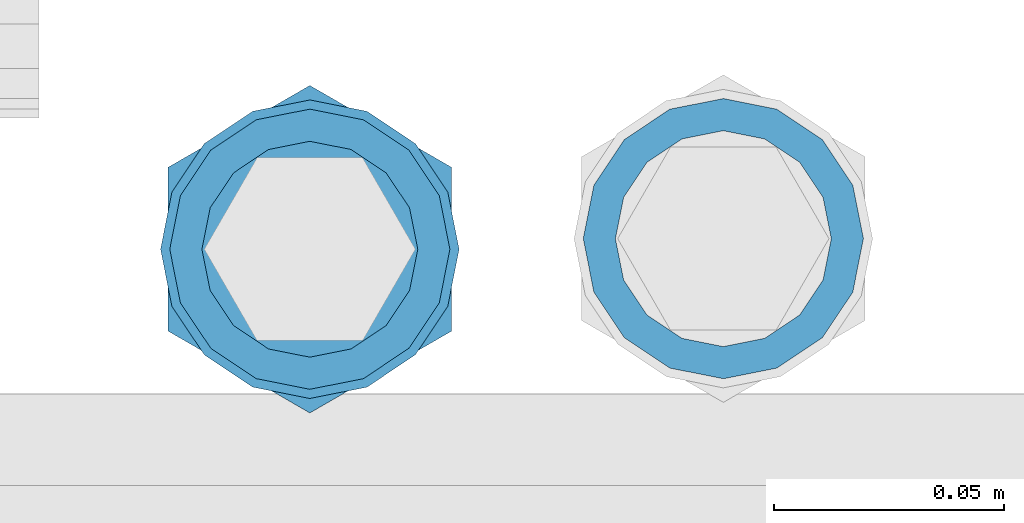
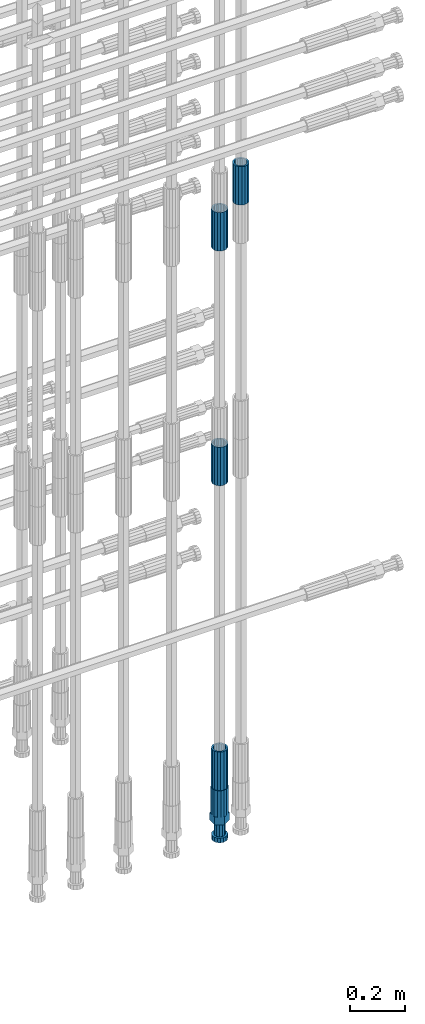
# One storey, part 103 of 119: 5 beams.
"""IFC2X3 building model written with IfcOpenShell, lengths in millimetres."""

import ifcopenshell
import ifcopenshell.guid

model = None  # the IFC model being written
_history = None  # IfcOwnerHistory: only IFC2X3 demands one
_inside = {}  # id of a spatial element -> (the spatial element, [elements in it])
_under = {}  # id of a project, library or spatial element -> (it, [spatial elements below it])
_declared = {}  # id of a project -> (the project, [libraries it declares])
_typed = {}  # id of a type object -> (the type object, [elements of that type])
_made_of = {}  # id of a material, layer set ... -> (it, [elements and type objects made of it])


def new_model(schema):
    """Start an empty IFC model of exactly this schema.

    Asked for "IFC4X3", IfcOpenShell would pick the latest addendum, in which some entities
    have other attributes; the version numbers below select the first issue.
    IFC2X3 requires an IfcOwnerHistory on every rooted entity: one is made here for all.
    """
    global model, _history
    if schema == "IFC4X3":
        model = ifcopenshell.file(schema_version=(4, 3, 0, 0))
    else:
        model = ifcopenshell.file(schema=schema)
    _inside.clear()
    _under.clear()
    _declared.clear()
    _typed.clear()
    _made_of.clear()
    _history = None
    if model.schema == "IFC2X3":
        org = make("IfcOrganization", Name="unknown")
        user = make(
            "IfcPersonAndOrganization",
            ThePerson=make("IfcPerson", FamilyName="unknown"),
            TheOrganization=org,
        )
        app = make(
            "IfcApplication",
            ApplicationDeveloper=org,
            Version="unknown",
            ApplicationFullName="unknown",
            ApplicationIdentifier="unknown",
        )
        _history = make(
            "IfcOwnerHistory",
            OwningUser=user,
            OwningApplication=app,
            ChangeAction="ADDED",
            CreationDate=0,
        )
    return model


def make(cls, **values):
    """One entity of the class cls with the attributes given. An attribute that is None is left unset."""
    return model.create_entity(
        cls, **{name: value for name, value in values.items() if value is not None}
    )


def rooted(cls, **values):
    """An entity with a GlobalId (a new one), such as an element, a storey or a relation."""
    return make(cls, GlobalId=ifcopenshell.guid.new(), OwnerHistory=_history, **values)


def si_unit(unit_type, name, prefix=None):
    """IfcSIUnit, for example si_unit("LENGTHUNIT", "METRE", prefix="MILLI")."""
    return make("IfcSIUnit", UnitType=unit_type, Prefix=prefix, Name=name)


def assignment(units):
    """IfcUnitAssignment: the units of a project."""
    return None if units is None else make("IfcUnitAssignment", Units=units)


def point(xyz):
    """IfcCartesianPoint."""
    return None if xyz is None else make("IfcCartesianPoint", Coordinates=xyz)


def direction(xyz):
    """IfcDirection."""
    return None if xyz is None else make("IfcDirection", DirectionRatios=xyz)


def frame(location, z_axis=None, x_axis=None):
    """IfcAxis2Placement3D, a coordinate frame: its origin and axes. An axis left out is left unset."""
    return make(
        "IfcAxis2Placement3D",
        Location=point(location),
        Axis=direction(z_axis),
        RefDirection=direction(x_axis),
    )


def origin_with_axes():
    """The frame at (0, 0, 0) with the z axis (0, 0, 1) and the x axis (1, 0, 0) written out."""
    return frame((0.0, 0.0, 0.0), z_axis=(0.0, 0.0, 1.0), x_axis=(1.0, 0.0, 0.0))


def place(relative_to, where):
    """IfcLocalPlacement: puts the frame where relative to a parent placement (None: the world)."""
    return make(
        "IfcLocalPlacement", PlacementRelTo=relative_to, RelativePlacement=where
    )


def context(
    kind, dimensions, precision=None, world=None, true_north=None, identifier=None
):
    """IfcGeometricRepresentationContext, for example the 3D "Model" context."""
    return make(
        "IfcGeometricRepresentationContext",
        ContextIdentifier=identifier,
        ContextType=kind,
        CoordinateSpaceDimension=dimensions,
        Precision=precision,
        WorldCoordinateSystem=world,
        TrueNorth=true_north,
    )


def subcontext(parent, identifier, kind, view, scale=None):
    """IfcGeometricRepresentationSubContext, for example "Body" below "Model"."""
    return make(
        "IfcGeometricRepresentationSubContext",
        ContextIdentifier=identifier,
        ContextType=kind,
        ParentContext=parent,
        TargetScale=scale,
        TargetView=view,
    )


def project(units=None, contexts=None):
    """IfcProject with its units and contexts."""
    return rooted(
        "IfcProject",
        Name="project",
        RepresentationContexts=contexts,
        UnitsInContext=assignment(units),
    )


def spatial(cls, under=None, at=None, **own):
    """A site, building, storey or space (cls), placed at a placement, below another one or the project."""
    s = rooted(cls, ObjectPlacement=at, **own)
    if under is not None:
        _under.setdefault(under.id(), (under, []))[1].append(s)
    return s


def faces_of(points, faces, orient=None, outer=None):
    """IfcFace entities. A face is a list of loops; a loop is a list of indices into points, from 0.

    orient and outer hold one flag for each loop. By default every Orientation is true, the
    first loop of a face is its IfcFaceOuterBound and the others are IfcFaceBound.
    """
    made = []
    for i, loops in enumerate(faces):
        bounds = []
        for j, loop in enumerate(loops):
            is_outer = j == 0 if outer is None else outer[i][j]
            bounds.append(
                make(
                    "IfcFaceOuterBound" if is_outer else "IfcFaceBound",
                    Bound=make("IfcPolyLoop", Polygon=[points[k] for k in loop]),
                    Orientation=True if orient is None else orient[i][j],
                )
            )
        made.append(make("IfcFace", Bounds=bounds))
    return made


def faceted_brep(points, faces, orient=None, outer=None, voids=None):
    """IfcFacetedBrep: a solid bounded by flat faces; with voids (closed shells), ...WithVoids."""
    shared = [point(p) for p in points]
    hull = make("IfcClosedShell", CfsFaces=faces_of(shared, faces, orient, outer))
    if voids is None:
        return make("IfcFacetedBrep", Outer=hull)
    return make(
        "IfcFacetedBrepWithVoids",
        Outer=hull,
        Voids=[
            make(cls, CfsFaces=faces_of(shared, fs, o, b)) for cls, fs, o, b in voids
        ],
    )


def shape(context_of_items, identifier, shape_type, items):
    """IfcShapeRepresentation: the items that make up one representation, for example the "Body"."""
    return make(
        "IfcShapeRepresentation",
        ContextOfItems=context_of_items,
        RepresentationIdentifier=identifier,
        RepresentationType=shape_type,
        Items=items,
    )


def material(Name=None, Category=None):
    """IfcMaterial."""
    return make("IfcMaterial", Name=Name, Category=Category)


def made_of(thing, what):
    """Note that an element or type object is made of a material, layer set ...; save() writes the relation."""
    if what is not None:
        _made_of.setdefault(what.id(), (what, []))[1].append(thing)
    return thing


def type_object(cls, material=None, **own):
    """A type object (cls), such as IfcWallType, which elements share."""
    return made_of(rooted(cls, **own), material)


def element(
    cls,
    number,
    at=None,
    inside=None,
    cuts=None,
    type_object=None,
    material=None,
    context=None,
    identifier="Body",
    shape_type=None,
    held_by="IfcProductDefinitionShape",
    body=None,
    shapes=None,
    **own,
):
    """One element of the class cls, such as IfcWall. Its Tag is "e" and its number.

    at: its placement. inside: the storey or other place that contains it. cuts: it is an
    opening in that element (IfcRelVoidsElement). A single representation is given by context,
    identifier, shape_type and body (its items); several are given by shapes. held_by: the class
    of the entity that holds the representations. save() writes the other relations.
    """
    e = rooted(cls, Tag="e%d" % number, ObjectPlacement=at, **own)
    if body is not None:
        shapes = [shape(context, identifier, shape_type, body)]
    if shapes is not None:
        e.Representation = make(held_by, Representations=shapes)
    if inside is not None:
        _inside.setdefault(inside.id(), (inside, []))[1].append(e)
    if cuts is not None:
        rooted(
            "IfcRelVoidsElement", RelatingBuildingElement=cuts, RelatedOpeningElement=e
        )
    if type_object is not None:
        _typed.setdefault(type_object.id(), (type_object, []))[1].append(e)
    return made_of(e, material)


def aggregate(whole, parts):
    """IfcRelAggregates: a whole, such as a stair, and the parts it consists of."""
    return rooted("IfcRelAggregates", RelatingObject=whole, RelatedObjects=parts)


def save(model, path):
    """Write the relations noted so far, then the file.

    IfcRelAggregates (storeys below a building ...), IfcRelContainedInSpatialStructure (elements
    in a storey), IfcRelDefinesByType, IfcRelAssociatesMaterial and IfcRelDeclares: one each for
    every whole, place, type object, material and project.
    """
    for whole, parts in _under.values():
        aggregate(whole, parts)
    for where, things in _inside.values():
        rooted(
            "IfcRelContainedInSpatialStructure",
            RelatedElements=things,
            RelatingStructure=where,
        )
    for kind, things in _typed.values():
        rooted("IfcRelDefinesByType", RelatedObjects=things, RelatingType=kind)
    for what, things in _made_of.values():
        rooted("IfcRelAssociatesMaterial", RelatedObjects=things, RelatingMaterial=what)
    for by, libraries in _declared.values():
        rooted("IfcRelDeclares", RelatingContext=by, RelatedDefinitions=libraries)
    model.write(path)


model = new_model("IFC2X3")

# Units and contexts
model_context = context("Model", 3, precision=1e-05, world=origin_with_axes())
body_context = subcontext(model_context, "Body", "Model", "MODEL_VIEW")
ifc_project = project(units=[si_unit("LENGTHUNIT", "METRE", prefix="MILLI"), si_unit("AREAUNIT", "SQUARE_METRE"), si_unit("VOLUMEUNIT", "CUBIC_METRE"), si_unit("MASSUNIT", "GRAM", prefix="KILO"), si_unit("TIMEUNIT", "SECOND"), si_unit("PLANEANGLEUNIT", "RADIAN"), si_unit("SOLIDANGLEUNIT", "STERADIAN"), si_unit("THERMODYNAMICTEMPERATUREUNIT", "DEGREE_CELSIUS"), si_unit("LUMINOUSINTENSITYUNIT", "LUMEN")], contexts=[model_context])

# Site, building, storey
site_placement = place(None, origin_with_axes())
site = spatial("IfcSite", under=ifc_project, at=site_placement, CompositionType="ELEMENT")
building_placement = place(site_placement, origin_with_axes())
building = spatial("IfcBuilding", under=site, at=building_placement, Name="Undefined", CompositionType="ELEMENT")
storey_placement = place(building_placement, origin_with_axes())
storey = spatial("IfcBuildingStorey", under=building, at=storey_placement, Name="Undefined", CompositionType="ELEMENT", Elevation=0.0)

# Beams
ifc_material = material(Name="STEEL/S275")
beam_type_1 = type_object("IfcBeamType", PredefinedType="NOTDEFINED")
beam_1_placement = place(storey_placement, frame((2039119.0136987, 6205156.73095221, 21044.6068583132), z_axis=(-0.99999999999998, 1.98000110685822e-07, 0.0), x_axis=(0.0, 0.0, -1.0)))
element("IfcBeam", 1, at=beam_1_placement, inside=storey, type_object=beam_type_1, material=ifc_material, Name="AG40N", context=body_context, shape_type="Brep", body=[
    faceted_brep([(1.62981450557709e-09, -23.4999999990687, 0.0), (7.45058059692383e-09, -21.7111690142192, 8.99306066057534), (170.000002125278, -21.711168999318, 8.99306066022245), (170.000002127141, -23.4999999844003, -3.66071617463604e-10), (4.65661287307739e-09, -16.6170093587134, 16.6170093578889), (170.000002122484, -16.6170093440451, 16.6170093575288), (1.86264514923096e-09, -8.99306066217832, 21.7111690140277), (170.000002118759, -8.99306064750999, 21.7111690136603), (2.3283064365387e-10, 9.31322574615479e-10, 23.5), (170.000002114102, 1.28056854009628e-08, 23.4999999996485), (-6.51925802230835e-09, 8.99306065868586, 21.7111690140241), (170.00000211224, 8.99306067335419, 21.7111690136639), (-7.45058059692383e-09, 16.6170093561523, 16.6170093578853), (170.000002109446, 16.6170093708206, 16.6170093575324), (-9.31322574615479e-09, 21.711169013055, 8.99306066057534), (170.000002108514, 21.7111690277234, 8.99306066022245), (-1.16415321826935e-09, 23.5000000009313, 0.0), (170.000002108514, 23.5000000144355, -3.66071617463604e-10), (-8.38190317153931e-09, 21.7111690151505, -8.99306066059444), (170.000002110377, 21.7111690300517, -8.9930606609546), (-5.58793544769287e-09, 16.6170093598776, -16.6170093579008), (170.000002113171, 16.6170093745459, -16.6170093582609), (-9.31322574615479e-10, 8.99306066334248, -21.7111690140396), (170.000002115965, 8.99306067801081, -21.7111690143961), (2.3283064365387e-10, 9.31322574615479e-10, -23.5), (170.00000211969, 1.7927959561348e-08, -23.5000000003843), (5.58793544769287e-09, -8.99306065752171, -21.7111690140396), (170.000002123415, -8.99306064285338, -21.7111690143961), (8.38190317153931e-09, -16.6170093549881, -16.6170093579008), (170.000002125278, -16.6170093403198, -16.6170093582646), (9.31322574615479e-09, -21.7111690121237, -8.99306066059444), (170.000002127141, -21.7111689972226, -8.9930606609546), (1.11758708953857e-08, -30.4999999990687, -9.54969436861575e-12), (1.30385160446167e-08, -28.1783257392235, -11.6718446871514), (170.000002129003, -28.1783257243223, -11.6718446875116), (170.000002129935, -30.4999999841675, -3.66071617463604e-10), (1.02445483207703e-08, -21.5667568228673, -21.5667568262129), (170.000002128072, -21.566756808199, -21.5667568265694), (7.45058059692383e-09, -11.6718446831219, -28.1783257416196), (170.000002125278, -11.6718446684536, -28.1783257419834), (3.72529029846191e-09, 3.95812094211578e-09, -30.5000000000277), (170.00000211969, 1.83936208486557e-08, -30.5000000003879), (-9.31322574615479e-10, 11.6718446905725, -28.1783257416232), (170.000002115965, 11.6718447052408, -28.1783257419797), (-6.51925802230835e-09, 21.5667568286881, -21.5667568262093), (170.000002110377, 21.5667568433564, -21.5667568265694), (-9.31322574615479e-09, 28.178325742716, -11.6718446871478), (170.000002108514, 28.1783257573843, -11.6718446875079), (-1.21071934700012e-08, 30.5, -5.91171556152403e-12), (170.000002106652, 30.5000000144355, -3.62433638656512e-10), (-1.21071934700012e-08, 28.1783257401548, 11.6718446871359), (170.00000210572, 28.1783257548232, 11.6718446867794), (-1.02445483207703e-08, 21.5667568240315, 21.5667568261974), (170.000002107583, 21.566756838467, 21.5667568258409), (-7.45058059692383e-09, 11.671844684286, 28.1783257416041), (170.000002110377, 11.6718446989544, 28.178325741244), (-2.79396772384644e-09, -2.56113708019257e-09, 30.5000000000159), (170.000002114102, 1.18743628263474e-08, 30.4999999996558), (1.86264514923096e-09, -11.6718446896411, 28.1783257416114), (170.000002118759, -11.67184467474, 28.178325741244), (7.45058059692383e-09, -21.5667568275239, 21.5667568261974), (170.000002123415, -21.5667568126228, 21.5667568258373), (1.02445483207703e-08, -28.1783257415518, 11.6718446871359), (170.000002127141, -28.1783257271163, 11.6718446867794)], [[[0, 1, 2, 3]], [[1, 4, 5, 2]], [[4, 6, 7, 5]], [[6, 8, 9, 7]], [[8, 10, 11, 9]], [[10, 12, 13, 11]], [[12, 14, 15, 13]], [[14, 16, 17, 15]], [[16, 18, 19, 17]], [[18, 20, 21, 19]], [[20, 22, 23, 21]], [[22, 24, 25, 23]], [[24, 26, 27, 25]], [[26, 28, 29, 27]], [[28, 30, 31, 29]], [[30, 0, 3, 31]], [[32, 33, 34, 35]], [[33, 36, 37, 34]], [[36, 38, 39, 37]], [[38, 40, 41, 39]], [[40, 42, 43, 41]], [[42, 44, 45, 43]], [[44, 46, 47, 45]], [[46, 48, 49, 47]], [[48, 50, 51, 49]], [[50, 52, 53, 51]], [[52, 54, 55, 53]], [[54, 56, 57, 55]], [[56, 58, 59, 57]], [[58, 60, 61, 59]], [[60, 62, 63, 61]], [[62, 32, 35, 63]], [[37, 39, 41, 43, 45, 47, 49, 51, 53, 55, 57, 59, 61, 63, 35, 34], [5, 7, 9, 11, 13, 15, 17, 19, 21, 23, 25, 27, 29, 31, 3, 2]], [[62, 60, 58, 56, 54, 52, 50, 48, 46, 44, 42, 40, 38, 36, 33, 32], [30, 28, 26, 24, 22, 20, 18, 16, 14, 12, 10, 8, 6, 4, 1, 0]]]),
])
beam_2_placement = place(storey_placement, frame((2039028.98112118, 6205154.42663664, 19667.715729163), z_axis=(1.0, 0.0, 0.0), x_axis=(0.0, 0.0, 1.0)))
element("IfcBeam", 2, at=beam_2_placement, inside=storey, type_object=beam_type_1, material=ifc_material, Name="AG40N", context=body_context, shape_type="Brep", body=[
    faceted_brep([(1.62981450557709e-09, -23.4999999990687, 0.0), (7.45058059692383e-09, -21.7111690142192, 8.99306066057534), (170.000002125278, -21.711168999318, 8.99306066022245), (170.000002127141, -23.4999999844003, -3.66071617463604e-10), (4.65661287307739e-09, -16.6170093587134, 16.6170093578889), (170.000002122484, -16.6170093440451, 16.6170093575288), (1.86264514923096e-09, -8.99306066217832, 21.7111690140277), (170.000002118759, -8.99306064750999, 21.7111690136603), (2.3283064365387e-10, 9.31322574615479e-10, 23.5), (170.000002114102, 1.28056854009628e-08, 23.4999999996485), (-6.51925802230835e-09, 8.99306065868586, 21.7111690140241), (170.00000211224, 8.99306067335419, 21.7111690136639), (-7.45058059692383e-09, 16.6170093561523, 16.6170093578853), (170.000002109446, 16.6170093708206, 16.6170093575324), (-9.31322574615479e-09, 21.711169013055, 8.99306066057534), (170.000002108514, 21.7111690277234, 8.99306066022245), (-1.16415321826935e-09, 23.5000000009313, 0.0), (170.000002108514, 23.5000000144355, -3.66071617463604e-10), (-8.38190317153931e-09, 21.7111690151505, -8.99306066059444), (170.000002110377, 21.7111690300517, -8.9930606609546), (-5.58793544769287e-09, 16.6170093598776, -16.6170093579008), (170.000002113171, 16.6170093745459, -16.6170093582609), (-9.31322574615479e-10, 8.99306066334248, -21.7111690140396), (170.000002115965, 8.99306067801081, -21.7111690143961), (2.3283064365387e-10, 9.31322574615479e-10, -23.5), (170.00000211969, 1.7927959561348e-08, -23.5000000003843), (5.58793544769287e-09, -8.99306065752171, -21.7111690140396), (170.000002123415, -8.99306064285338, -21.7111690143961), (8.38190317153931e-09, -16.6170093549881, -16.6170093579008), (170.000002125278, -16.6170093403198, -16.6170093582646), (9.31322574615479e-09, -21.7111690121237, -8.99306066059444), (170.000002127141, -21.7111689972226, -8.9930606609546), (1.11758708953857e-08, -30.4999999990687, -9.54969436861575e-12), (1.30385160446167e-08, -28.1783257392235, -11.6718446871514), (170.000002129003, -28.1783257243223, -11.6718446875116), (170.000002129935, -30.4999999841675, -3.66071617463604e-10), (1.02445483207703e-08, -21.5667568228673, -21.5667568262129), (170.000002128072, -21.566756808199, -21.5667568265694), (7.45058059692383e-09, -11.6718446831219, -28.1783257416196), (170.000002125278, -11.6718446684536, -28.1783257419834), (3.72529029846191e-09, 3.95812094211578e-09, -30.5000000000277), (170.00000211969, 1.83936208486557e-08, -30.5000000003879), (-9.31322574615479e-10, 11.6718446905725, -28.1783257416232), (170.000002115965, 11.6718447052408, -28.1783257419797), (-6.51925802230835e-09, 21.5667568286881, -21.5667568262093), (170.000002110377, 21.5667568433564, -21.5667568265694), (-9.31322574615479e-09, 28.178325742716, -11.6718446871478), (170.000002108514, 28.1783257573843, -11.6718446875079), (-1.21071934700012e-08, 30.5, -5.91171556152403e-12), (170.000002106652, 30.5000000144355, -3.62433638656512e-10), (-1.21071934700012e-08, 28.1783257401548, 11.6718446871359), (170.00000210572, 28.1783257548232, 11.6718446867794), (-1.02445483207703e-08, 21.5667568240315, 21.5667568261974), (170.000002107583, 21.566756838467, 21.5667568258409), (-7.45058059692383e-09, 11.671844684286, 28.1783257416041), (170.000002110377, 11.6718446989544, 28.178325741244), (-2.79396772384644e-09, -2.56113708019257e-09, 30.5000000000159), (170.000002114102, 1.18743628263474e-08, 30.4999999996558), (1.86264514923096e-09, -11.6718446896411, 28.1783257416114), (170.000002118759, -11.67184467474, 28.178325741244), (7.45058059692383e-09, -21.5667568275239, 21.5667568261974), (170.000002123415, -21.5667568126228, 21.5667568258373), (1.02445483207703e-08, -28.1783257415518, 11.6718446871359), (170.000002127141, -28.1783257271163, 11.6718446867794)], [[[0, 1, 2, 3]], [[1, 4, 5, 2]], [[4, 6, 7, 5]], [[6, 8, 9, 7]], [[8, 10, 11, 9]], [[10, 12, 13, 11]], [[12, 14, 15, 13]], [[14, 16, 17, 15]], [[16, 18, 19, 17]], [[18, 20, 21, 19]], [[20, 22, 23, 21]], [[22, 24, 25, 23]], [[24, 26, 27, 25]], [[26, 28, 29, 27]], [[28, 30, 31, 29]], [[30, 0, 3, 31]], [[32, 33, 34, 35]], [[33, 36, 37, 34]], [[36, 38, 39, 37]], [[38, 40, 41, 39]], [[40, 42, 43, 41]], [[42, 44, 45, 43]], [[44, 46, 47, 45]], [[46, 48, 49, 47]], [[48, 50, 51, 49]], [[50, 52, 53, 51]], [[52, 54, 55, 53]], [[54, 56, 57, 55]], [[56, 58, 59, 57]], [[58, 60, 61, 59]], [[60, 62, 63, 61]], [[62, 32, 35, 63]], [[37, 39, 41, 43, 45, 47, 49, 51, 53, 55, 57, 59, 61, 63, 35, 34], [5, 7, 9, 11, 13, 15, 17, 19, 21, 23, 25, 27, 29, 31, 3, 2]], [[62, 60, 58, 56, 54, 52, 50, 48, 46, 44, 42, 40, 38, 36, 33, 32], [30, 28, 26, 24, 22, 20, 18, 16, 14, 12, 10, 8, 6, 4, 1, 0]]]),
])
beam_3_placement = place(storey_placement, frame((2039028.98112118, 6205154.42663665, 18490.9668583139), z_axis=(-0.99999999999998, 1.98000110685822e-07, 0.0), x_axis=(0.0, 0.0, -1.0)))
element("IfcBeam", 3, at=beam_3_placement, inside=storey, type_object=beam_type_1, material=ifc_material, Name="AG40N", context=body_context, shape_type="Brep", body=[
    faceted_brep([(1.62981450557709e-09, -23.4999999990687, 0.0), (7.45058059692383e-09, -21.7111690142192, 8.99306066057534), (170.000002125278, -21.711168999318, 8.99306066022245), (170.000002127141, -23.4999999844003, -3.66071617463604e-10), (4.65661287307739e-09, -16.6170093587134, 16.6170093578889), (170.000002122484, -16.6170093440451, 16.6170093575288), (1.86264514923096e-09, -8.99306066217832, 21.7111690140277), (170.000002118759, -8.99306064750999, 21.7111690136603), (2.3283064365387e-10, 9.31322574615479e-10, 23.5), (170.000002114102, 1.28056854009628e-08, 23.4999999996485), (-6.51925802230835e-09, 8.99306065868586, 21.7111690140241), (170.00000211224, 8.99306067335419, 21.7111690136639), (-7.45058059692383e-09, 16.6170093561523, 16.6170093578853), (170.000002109446, 16.6170093708206, 16.6170093575324), (-9.31322574615479e-09, 21.711169013055, 8.99306066057534), (170.000002108514, 21.7111690277234, 8.99306066022245), (-1.16415321826935e-09, 23.5000000009313, 0.0), (170.000002108514, 23.5000000144355, -3.66071617463604e-10), (-8.38190317153931e-09, 21.7111690151505, -8.99306066059444), (170.000002110377, 21.7111690300517, -8.9930606609546), (-5.58793544769287e-09, 16.6170093598776, -16.6170093579008), (170.000002113171, 16.6170093745459, -16.6170093582609), (-9.31322574615479e-10, 8.99306066334248, -21.7111690140396), (170.000002115965, 8.99306067801081, -21.7111690143961), (2.3283064365387e-10, 9.31322574615479e-10, -23.5), (170.00000211969, 1.7927959561348e-08, -23.5000000003843), (5.58793544769287e-09, -8.99306065752171, -21.7111690140396), (170.000002123415, -8.99306064285338, -21.7111690143961), (8.38190317153931e-09, -16.6170093549881, -16.6170093579008), (170.000002125278, -16.6170093403198, -16.6170093582646), (9.31322574615479e-09, -21.7111690121237, -8.99306066059444), (170.000002127141, -21.7111689972226, -8.9930606609546), (1.11758708953857e-08, -30.4999999990687, -9.54969436861575e-12), (1.30385160446167e-08, -28.1783257392235, -11.6718446871514), (170.000002129003, -28.1783257243223, -11.6718446875116), (170.000002129935, -30.4999999841675, -3.66071617463604e-10), (1.02445483207703e-08, -21.5667568228673, -21.5667568262129), (170.000002128072, -21.566756808199, -21.5667568265694), (7.45058059692383e-09, -11.6718446831219, -28.1783257416196), (170.000002125278, -11.6718446684536, -28.1783257419834), (3.72529029846191e-09, 3.95812094211578e-09, -30.5000000000277), (170.00000211969, 1.83936208486557e-08, -30.5000000003879), (-9.31322574615479e-10, 11.6718446905725, -28.1783257416232), (170.000002115965, 11.6718447052408, -28.1783257419797), (-6.51925802230835e-09, 21.5667568286881, -21.5667568262093), (170.000002110377, 21.5667568433564, -21.5667568265694), (-9.31322574615479e-09, 28.178325742716, -11.6718446871478), (170.000002108514, 28.1783257573843, -11.6718446875079), (-1.21071934700012e-08, 30.5, -5.91171556152403e-12), (170.000002106652, 30.5000000144355, -3.62433638656512e-10), (-1.21071934700012e-08, 28.1783257401548, 11.6718446871359), (170.00000210572, 28.1783257548232, 11.6718446867794), (-1.02445483207703e-08, 21.5667568240315, 21.5667568261974), (170.000002107583, 21.566756838467, 21.5667568258409), (-7.45058059692383e-09, 11.671844684286, 28.1783257416041), (170.000002110377, 11.6718446989544, 28.178325741244), (-2.79396772384644e-09, -2.56113708019257e-09, 30.5000000000159), (170.000002114102, 1.18743628263474e-08, 30.4999999996558), (1.86264514923096e-09, -11.6718446896411, 28.1783257416114), (170.000002118759, -11.67184467474, 28.178325741244), (7.45058059692383e-09, -21.5667568275239, 21.5667568261974), (170.000002123415, -21.5667568126228, 21.5667568258373), (1.02445483207703e-08, -28.1783257415518, 11.6718446871359), (170.000002127141, -28.1783257271163, 11.6718446867794)], [[[0, 1, 2, 3]], [[1, 4, 5, 2]], [[4, 6, 7, 5]], [[6, 8, 9, 7]], [[8, 10, 11, 9]], [[10, 12, 13, 11]], [[12, 14, 15, 13]], [[14, 16, 17, 15]], [[16, 18, 19, 17]], [[18, 20, 21, 19]], [[20, 22, 23, 21]], [[22, 24, 25, 23]], [[24, 26, 27, 25]], [[26, 28, 29, 27]], [[28, 30, 31, 29]], [[30, 0, 3, 31]], [[32, 33, 34, 35]], [[33, 36, 37, 34]], [[36, 38, 39, 37]], [[38, 40, 41, 39]], [[40, 42, 43, 41]], [[42, 44, 45, 43]], [[44, 46, 47, 45]], [[46, 48, 49, 47]], [[48, 50, 51, 49]], [[50, 52, 53, 51]], [[52, 54, 55, 53]], [[54, 56, 57, 55]], [[56, 58, 59, 57]], [[58, 60, 61, 59]], [[60, 62, 63, 61]], [[62, 32, 35, 63]], [[37, 39, 41, 43, 45, 47, 49, 51, 53, 55, 57, 59, 61, 63, 35, 34], [5, 7, 9, 11, 13, 15, 17, 19, 21, 23, 25, 27, 29, 31, 3, 2]], [[62, 60, 58, 56, 54, 52, 50, 48, 46, 44, 42, 40, 38, 36, 33, 32], [30, 28, 26, 24, 22, 20, 18, 16, 14, 12, 10, 8, 6, 4, 1, 0]]]),
])
beam_4_placement = place(storey_placement, frame((2039028.98112118, 6205154.42663664, 20704.605729163), z_axis=(1.0, 0.0, 0.0), x_axis=(0.0, 0.0, 1.0)))
element("IfcBeam", 4, at=beam_4_placement, inside=storey, type_object=beam_type_1, material=ifc_material, Name="AG40N", context=body_context, shape_type="Brep", body=[
    faceted_brep([(1.62981450557709e-09, -23.4999999990687, 0.0), (7.45058059692383e-09, -21.7111690142192, 8.99306066057534), (170.000002125278, -21.711168999318, 8.99306066022245), (170.000002127141, -23.4999999844003, -3.66071617463604e-10), (4.65661287307739e-09, -16.6170093587134, 16.6170093578889), (170.000002122484, -16.6170093440451, 16.6170093575288), (1.86264514923096e-09, -8.99306066217832, 21.7111690140277), (170.000002118759, -8.99306064750999, 21.7111690136603), (2.3283064365387e-10, 9.31322574615479e-10, 23.5), (170.000002114102, 1.28056854009628e-08, 23.4999999996485), (-6.51925802230835e-09, 8.99306065868586, 21.7111690140241), (170.00000211224, 8.99306067335419, 21.7111690136639), (-7.45058059692383e-09, 16.6170093561523, 16.6170093578853), (170.000002109446, 16.6170093708206, 16.6170093575324), (-9.31322574615479e-09, 21.711169013055, 8.99306066057534), (170.000002108514, 21.7111690277234, 8.99306066022245), (-1.16415321826935e-09, 23.5000000009313, 0.0), (170.000002108514, 23.5000000144355, -3.66071617463604e-10), (-8.38190317153931e-09, 21.7111690151505, -8.99306066059444), (170.000002110377, 21.7111690300517, -8.9930606609546), (-5.58793544769287e-09, 16.6170093598776, -16.6170093579008), (170.000002113171, 16.6170093745459, -16.6170093582609), (-9.31322574615479e-10, 8.99306066334248, -21.7111690140396), (170.000002115965, 8.99306067801081, -21.7111690143961), (2.3283064365387e-10, 9.31322574615479e-10, -23.5), (170.00000211969, 1.7927959561348e-08, -23.5000000003843), (5.58793544769287e-09, -8.99306065752171, -21.7111690140396), (170.000002123415, -8.99306064285338, -21.7111690143961), (8.38190317153931e-09, -16.6170093549881, -16.6170093579008), (170.000002125278, -16.6170093403198, -16.6170093582646), (9.31322574615479e-09, -21.7111690121237, -8.99306066059444), (170.000002127141, -21.7111689972226, -8.9930606609546), (1.11758708953857e-08, -30.4999999990687, -9.54969436861575e-12), (1.30385160446167e-08, -28.1783257392235, -11.6718446871514), (170.000002129003, -28.1783257243223, -11.6718446875116), (170.000002129935, -30.4999999841675, -3.66071617463604e-10), (1.02445483207703e-08, -21.5667568228673, -21.5667568262129), (170.000002128072, -21.566756808199, -21.5667568265694), (7.45058059692383e-09, -11.6718446831219, -28.1783257416196), (170.000002125278, -11.6718446684536, -28.1783257419834), (3.72529029846191e-09, 3.95812094211578e-09, -30.5000000000277), (170.00000211969, 1.83936208486557e-08, -30.5000000003879), (-9.31322574615479e-10, 11.6718446905725, -28.1783257416232), (170.000002115965, 11.6718447052408, -28.1783257419797), (-6.51925802230835e-09, 21.5667568286881, -21.5667568262093), (170.000002110377, 21.5667568433564, -21.5667568265694), (-9.31322574615479e-09, 28.178325742716, -11.6718446871478), (170.000002108514, 28.1783257573843, -11.6718446875079), (-1.21071934700012e-08, 30.5, -5.91171556152403e-12), (170.000002106652, 30.5000000144355, -3.62433638656512e-10), (-1.21071934700012e-08, 28.1783257401548, 11.6718446871359), (170.00000210572, 28.1783257548232, 11.6718446867794), (-1.02445483207703e-08, 21.5667568240315, 21.5667568261974), (170.000002107583, 21.566756838467, 21.5667568258409), (-7.45058059692383e-09, 11.671844684286, 28.1783257416041), (170.000002110377, 11.6718446989544, 28.178325741244), (-2.79396772384644e-09, -2.56113708019257e-09, 30.5000000000159), (170.000002114102, 1.18743628263474e-08, 30.4999999996558), (1.86264514923096e-09, -11.6718446896411, 28.1783257416114), (170.000002118759, -11.67184467474, 28.178325741244), (7.45058059692383e-09, -21.5667568275239, 21.5667568261974), (170.000002123415, -21.5667568126228, 21.5667568258373), (1.02445483207703e-08, -28.1783257415518, 11.6718446871359), (170.000002127141, -28.1783257271163, 11.6718446867794)], [[[0, 1, 2, 3]], [[1, 4, 5, 2]], [[4, 6, 7, 5]], [[6, 8, 9, 7]], [[8, 10, 11, 9]], [[10, 12, 13, 11]], [[12, 14, 15, 13]], [[14, 16, 17, 15]], [[16, 18, 19, 17]], [[18, 20, 21, 19]], [[20, 22, 23, 21]], [[22, 24, 25, 23]], [[24, 26, 27, 25]], [[26, 28, 29, 27]], [[28, 30, 31, 29]], [[30, 0, 3, 31]], [[32, 33, 34, 35]], [[33, 36, 37, 34]], [[36, 38, 39, 37]], [[38, 40, 41, 39]], [[40, 42, 43, 41]], [[42, 44, 45, 43]], [[44, 46, 47, 45]], [[46, 48, 49, 47]], [[48, 50, 51, 49]], [[50, 52, 53, 51]], [[52, 54, 55, 53]], [[54, 56, 57, 55]], [[56, 58, 59, 57]], [[58, 60, 61, 59]], [[60, 62, 63, 61]], [[62, 32, 35, 63]], [[37, 39, 41, 43, 45, 47, 49, 51, 53, 55, 57, 59, 61, 63, 35, 34], [5, 7, 9, 11, 13, 15, 17, 19, 21, 23, 25, 27, 29, 31, 3, 2]], [[62, 60, 58, 56, 54, 52, 50, 48, 46, 44, 42, 40, 38, 36, 33, 32], [30, 28, 26, 24, 22, 20, 18, 16, 14, 12, 10, 8, 6, 4, 1, 0]]]),
])
beam_type_2 = type_object("IfcBeamType", Name="ROD65", PredefinedType="NOTDEFINED")
beam_5_placement = place(storey_placement, frame((2039028.98112118, 6205154.42663665, 18320.9668583139), z_axis=(-0.99999999999998, 1.98000110685822e-07, 0.0), x_axis=(0.0, 0.0, -1.0)))
element("IfcBeam", 5, at=beam_5_placement, inside=storey, type_object=beam_type_2, material=ifc_material, Name="AGB40", ObjectType="ROD65", context=body_context, shape_type="Brep", body=[
    faceted_brep([(116.999999999069, 17.8249999252148, 30.8738056446964), (116.999999998137, 22.0056957420893, 23.632628078838), (116.999999999069, 12.4372115600854, 30.0260848066173), (116.999999999069, 8.17543111252598, 30.8738056446964), (117.000000000931, -17.8250000746921, 30.8738056446964), (150.200000001118, -17.8250000723638, 30.8738056446964), (150.199999999255, 17.8249999275431, 30.8738056446964), (117.000000000931, -8.17543109622784, 30.8738056446964), (117.000000001863, -22.0056959956419, 23.6326278985034), (117.000000000931, -12.4372115437873, 30.0260848066173), (117.000000001863, -35.6500000746455, -2.18278728425503e-10), (150.200000002049, -35.6500000723172, -2.18278728425503e-10), (117.000000001863, -30.8443149488885, 8.32369080289209), (117.000000001863, -30.8443149488885, -8.32369080355784), (117.000000002794, -32.4999999918509, 0.0), (117.000000000931, -17.8250000746921, -30.873805645133), (150.200000001118, -17.8250000723638, -30.873805645133), (117.000000001863, -22.0056959961075, -23.6326278982269), (117.000000000931, -8.17543109389953, -30.873805645133), (117.000000000931, -12.4372115437873, -30.0260848066173), (116.999999999069, 17.8249999252148, -30.873805645133), (150.199999999255, 17.8249999275431, -30.873805645133), (116.999999999069, 8.17543111019768, -30.873805645133), (116.999999999069, 12.4372115600854, -30.0260848066173), (116.999999998137, 22.005695742555, -23.6326280785652), (116.999999998137, 35.6499999251682, -2.18278728425503e-10), (150.199999998324, 35.6499999277294, -2.18278728425503e-10), (116.999999998137, 30.8443150522653, -8.32369036550881), (116.999999997206, 32.5000000081491, 0.0), (116.999999998137, 30.8443150522653, 8.32369036483942), (1.86264514923096e-09, -22.9809703885112, 22.9809703885621), (1.86264514923096e-09, -30.0260848065373, 12.4372115518672), (117.000000001863, -30.0260847983882, 12.4372115518672), (117.000000001863, -22.9809703803621, 22.9809703885621), (-1.86264514923096e-09, 22.9809703885112, -22.9809703885621), (-1.86264514923096e-09, 30.0260848065373, -12.4372115518672), (116.999999998137, 30.0260848146863, -12.4372115518672), (116.999999998137, 22.9809703966603, -22.9809703885621), (1.86264514923096e-09, -30.0260848065373, -12.4372115518672), (1.86264514923096e-09, -22.9809703885112, -22.9809703885621), (117.000000001863, -22.9809703803621, -22.9809703885621), (117.000000001863, -30.0260847983882, -12.4372115518672), (9.31322574615479e-10, -12.4372115519363, 30.0260848066173), (0.0, 0.0, 32.5), (-9.31322574615479e-10, 12.4372115519363, 30.0260848066173), (-1.86264514923096e-09, 22.9809703885112, 22.9809703885621), (-1.86264514923096e-09, 30.0260848065373, 12.4372115518672), (-2.79396772384644e-09, 32.5, 0.0), (-9.31322574615479e-10, 12.4372115519363, -30.0260848066173), (0.0, 0.0, -32.5), (9.31322574615479e-10, -12.4372115519363, -30.0260848066173), (2.79396772384644e-09, -32.5, 0.0), (116.999999998137, 22.9809703966603, 22.9809703885621), (116.999999998137, 30.0260848146863, 12.4372115518672), (117.0, 8.14907252788544e-09, -32.5), (117.0, 8.14907252788544e-09, 32.5), (150.200000000186, -10.5000000959262, 18.1865334791873), (150.199999999255, -9.59262251853943e-08, 20.9999999997126), (150.199999998324, 10.4999999040738, 18.1865334791873), (150.199999997392, 18.1865333835594, 10.4999999997126), (150.199999997392, 20.9999999040738, -2.87400325760245e-10), (150.199999997392, 18.1865333835594, -10.5000000002874), (150.199999998324, 10.4999999040738, -18.1865334797621), (150.199999999255, -9.59262251853943e-08, -21.0000000002874), (150.200000000186, -10.5000000959262, -18.1865334797621), (150.200000000186, -18.1865335754119, -10.5000000002874), (150.200000001118, -21.0000000959262, -2.87400325760245e-10), (150.200000000186, -18.1865335754119, 10.4999999997126), (210.979999999516, 10.4999999082647, 18.1865334791873), (210.979999999516, -9.17352735996246e-08, 20.9999999997126), (210.979999997653, 18.1865333877504, 10.4999999997126), (210.979999997653, 20.9999999082647, -2.87400325760245e-10), (210.979999997653, 18.1865333877504, -10.5000000002874), (210.979999999516, 10.4999999082647, -18.1865334797621), (210.979999999516, -9.17352735996246e-08, -21.0000000002874), (210.979999999516, -10.5000000917353, -18.1865334797621), (210.980000000447, -18.1865335712209, -10.5000000002874), (210.980000001378, -21.0000000917353, -2.87400325760245e-10), (210.980000000447, -18.1865335712209, 10.4999999997126), (210.979999999516, -10.5000000917353, 18.1865334791873), (211.001368402503, -27.7269939335529, -11.4911163272045), (211.003082515672, -21.2238095656503, -21.2238154190527), (231.002518340945, -21.2131946226582, -21.2132004554769), (231.000804228708, -27.7163789905608, -11.4805013636287), (211.001368415542, -11.4911086384673, -27.7269970399575), (231.000804241747, -11.4804936954752, -27.7163820763781), (210.996487061493, -0.0106066407170147, -30.0106107396168), (230.995922887698, 8.30227509140968e-06, -29.999995776041), (210.98918159306, 11.4698940692469, -27.7269970332745), (230.988617419265, 11.4805090120062, -27.7163820696951), (210.980564201251, 21.2025913291145, -21.2238154067054), (230.980000027455, 21.2132062721066, -21.2132004431296), (210.971946807578, 27.7057702087332, -11.4911163110701), (230.971382633783, 27.7163851517253, -11.4805013474943), (210.964641331695, 29.9893806746695, -0.0106149565435771), (230.9640771579, 29.9999956176616, 7.03221303410828e-09), (210.959759964608, 27.7057637346443, 11.4698863966551), (230.959195790812, 27.7163786776364, 11.4805013602345), (210.958045851439, 21.2025793667417, 21.2025854885032), (230.957481677644, 21.2131943097338, 21.2132004520827), (210.959759951569, 11.4698784395587, 27.705767109408), (230.959195776843, 11.4804933823179, 27.7163820729838), (210.964641305618, -0.0106235581915826, 29.9893808090674), (230.964077131823, -8.61519947648048e-06, 29.9999957726432), (210.971946774051, -11.4911242681555, 27.7057671027251), (230.971382599324, -11.4805093251634, 27.7163820663009), (210.98056416586, -21.2238215280231, 21.2025854761559), (230.979999991134, -21.2132065852638, 21.2132004397354), (210.989181559533, -27.7270004076418, 11.4698863805206), (230.988617384806, -27.7163854646496, 11.4805013441), (210.996487035416, -30.0106108735781, -0.0106149740058754), (230.995922861621, -29.999995930586, -1.04300852399319e-08)], [[[0, 1, 2, 3]], [[4, 5, 6, 0, 3, 7]], [[8, 4, 7, 9]], [[10, 11, 5, 4, 8, 12]], [[13, 10, 12, 14]], [[15, 16, 11, 10, 13, 17]], [[18, 15, 17, 19]], [[20, 21, 16, 15, 18, 22]], [[20, 22, 23, 24]], [[25, 26, 21, 20, 24, 27]], [[25, 27, 28, 29]], [[30, 31, 32, 33]], [[34, 35, 36, 37]], [[38, 39, 40, 41]], [[31, 30, 42, 43, 44, 45, 46, 47, 35, 34, 48, 49, 50, 39, 38, 51]], [[46, 45, 52, 53]], [[28, 47, 46, 53, 29]], [[27, 36, 35, 47, 28]], [[24, 37, 36, 27]], [[23, 48, 34, 37, 24]], [[22, 54, 49, 48, 23]], [[18, 54, 22]], [[19, 50, 49, 54, 18]], [[17, 40, 39, 50, 19]], [[13, 41, 40, 17]], [[14, 51, 38, 41, 13]], [[12, 32, 31, 51, 14]], [[8, 33, 32, 12]], [[9, 42, 30, 33, 8]], [[7, 55, 43, 42, 9]], [[3, 55, 7]], [[2, 44, 43, 55, 3]], [[1, 52, 45, 44, 2]], [[29, 53, 52, 1]], [[0, 6, 26, 25, 29, 1]], [[5, 11, 16, 21, 26, 6], [56, 57, 58, 59, 60, 61, 62, 63, 64, 65, 66, 67]], [[68, 58, 57, 69]], [[70, 59, 58, 68]], [[71, 60, 59, 70]], [[72, 61, 60, 71]], [[73, 62, 61, 72]], [[74, 63, 62, 73]], [[75, 64, 63, 74]], [[76, 65, 64, 75]], [[77, 66, 65, 76]], [[78, 67, 66, 77]], [[79, 56, 67, 78]], [[69, 57, 56, 79]], [[80, 81, 82, 83]], [[81, 84, 85, 82]], [[84, 86, 87, 85]], [[86, 88, 89, 87]], [[88, 90, 91, 89]], [[90, 92, 93, 91]], [[92, 94, 95, 93]], [[94, 96, 97, 95]], [[96, 98, 99, 97]], [[98, 100, 101, 99]], [[100, 102, 103, 101]], [[102, 104, 105, 103]], [[104, 106, 107, 105]], [[106, 108, 109, 107]], [[108, 110, 111, 109]], [[82, 85, 87, 89, 91, 93, 95, 97, 99, 101, 103, 105, 107, 109, 111, 83]], [[110, 80, 83, 111]], [[108, 106, 104, 102, 100, 98, 96, 94, 92, 90, 88, 86, 84, 81, 80, 110], [78, 77, 76, 75, 74, 73, 72, 71, 70, 68, 69, 79]]]),
])

save(model, "model.ifc")
